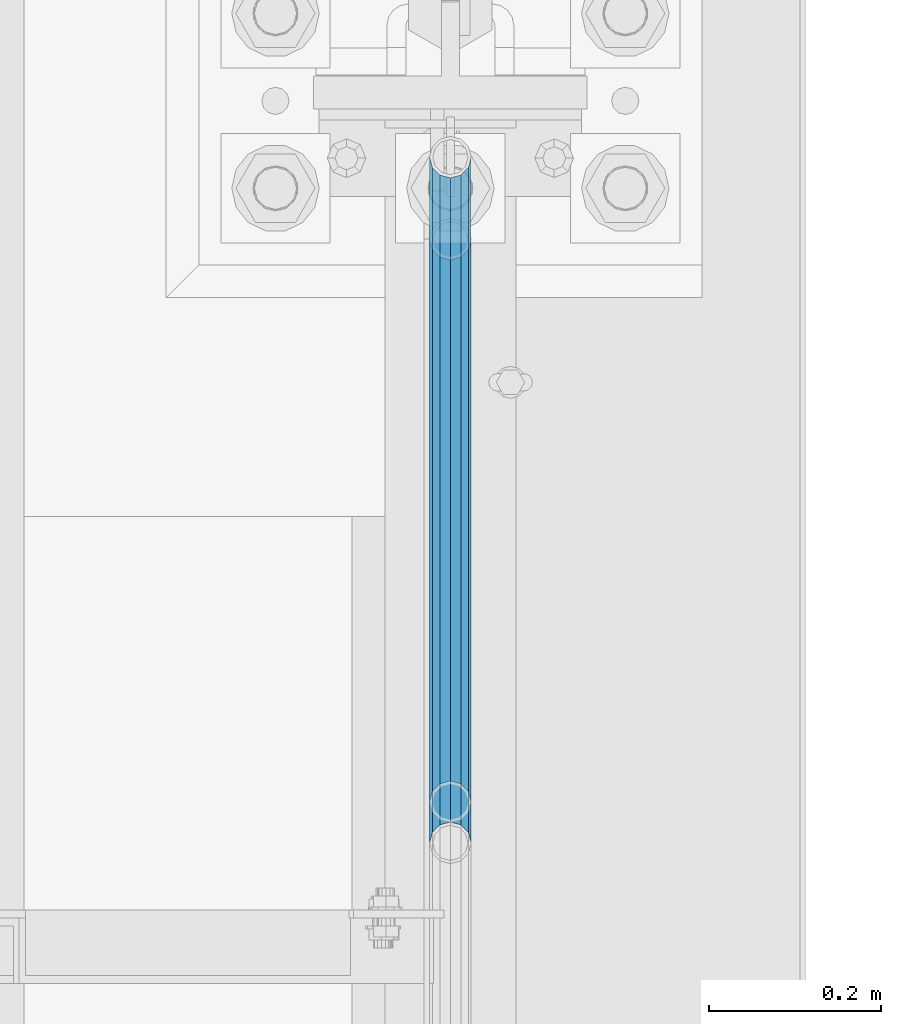
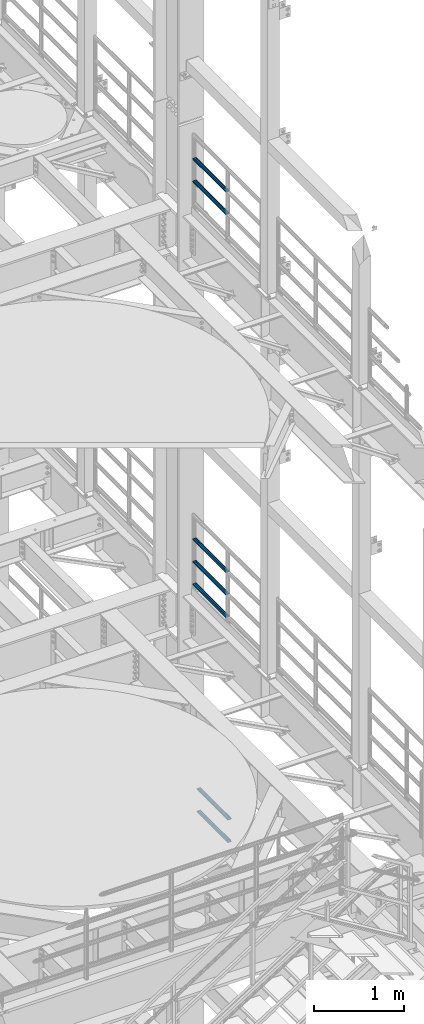
# One storey, part 1270 of 1876: 7 beams, 3 elements without a shape of their own.
"""IFC2X3 building model written with IfcOpenShell, lengths in millimetres."""

from ifc_helpers import new_model, si_unit, frame, origin_with_axes, place, context, subcontext, project, spatial, faceted_brep, material, type_object, element, aggregate, save


model = new_model("IFC2X3")

# Units and contexts
model_context = context("Model", 3, precision=1e-05, world=origin_with_axes())
body_context = subcontext(model_context, "Body", "Model", "MODEL_VIEW")
ifc_project = project(units=[si_unit("LENGTHUNIT", "METRE", prefix="MILLI"), si_unit("AREAUNIT", "SQUARE_METRE"), si_unit("VOLUMEUNIT", "CUBIC_METRE"), si_unit("MASSUNIT", "GRAM", prefix="KILO"), si_unit("TIMEUNIT", "SECOND"), si_unit("PLANEANGLEUNIT", "RADIAN"), si_unit("SOLIDANGLEUNIT", "STERADIAN"), si_unit("THERMODYNAMICTEMPERATUREUNIT", "DEGREE_CELSIUS"), si_unit("LUMINOUSINTENSITYUNIT", "LUMEN")], contexts=[model_context])

# Site, building, storey
site_placement = place(None, origin_with_axes())
site = spatial("IfcSite", under=ifc_project, at=site_placement, CompositionType="ELEMENT")
building_placement = place(site_placement, origin_with_axes())
building = spatial("IfcBuilding", under=site, at=building_placement, Name="Undefined", CompositionType="ELEMENT")
storey_placement = place(building_placement, origin_with_axes())
storey = spatial("IfcBuildingStorey", under=building, at=storey_placement, Name="Undefined", CompositionType="ELEMENT", Elevation=0.0)

# Assembly, beams
assembly_1_placement = place(storey_placement, origin_with_axes())
assembly_1 = element("IfcElementAssembly", 1, at=assembly_1_placement, inside=storey, Name="RAIL", AssemblyPlace="NOTDEFINED", PredefinedType="RIGID_FRAME")
ifc_material = material()
beam_type = type_object("IfcBeamType", Name="PIPE1-1/2SCH40", PredefinedType="NOTDEFINED")
beam_1_placement = place(assembly_1_placement, frame((7620.0, 430.212499999995, 13776.325), z_axis=(0.0, 0.0, -1.0), x_axis=(0.0, 1.0, 0.0)))
beam_1 = element("IfcBeam", 2, at=beam_1_placement, type_object=beam_type, material=ifc_material, Name="RAIL", ObjectType="PIPE1-1/2SCH40", context=body_context, shape_type="Brep", body=[
    faceted_brep([(0.0, 24.1299999999992, 0.0), (12.0650000000064, 20.8971929933177, -12.0649999999987), (12.0650000000064, 20.8971929933177, 12.0649999999987), (12.0650000000064, -20.8971929933177, 12.0649999999987), (12.0650000000064, -20.8971929933177, -12.0649999999987), (0.0, -24.1299999999992, 0.0), (20.8971929933249, -12.0650000000005, 20.8971929933177), (20.8971929933249, -12.0650000000005, 15.8661214311796), (15.2545715621445, -17.7076214311801, 10.2235000000001), (12.5151929933249, -20.4470000000001, 0.0), (15.2545715621445, -17.7076214311801, -10.2235000000001), (20.8971929933249, -12.0650000000005, -15.8661214311796), (20.8971929933249, -12.0650000000005, -20.8971929933177), (24.1300000000063, 0.0, -20.4470000000001), (24.1300000000063, 0.0, -24.130000000001), (21.3906214311868, -10.2235000000001, -17.7076214311819), (21.3906214311868, 10.2235000000001, -17.7076214311819), (20.8971929933249, 12.0650000000005, -15.8661214311796), (20.8971929933249, 12.0650000000005, -20.8971929933177), (15.2545715621445, 17.7076214311801, -10.2235000000001), (12.5151929933249, 20.4470000000001, 0.0), (15.2545715621445, 17.7076214311801, 10.2235000000001), (20.8971929933249, 12.0650000000005, 15.8661214311796), (20.8971929933249, 12.0650000000005, 20.8971929933177), (21.3906214311868, 10.2235000000001, 17.7076214311819), (24.1300000000064, 0.0, 20.4470000000001), (24.1300000000064, 0.0, 24.130000000001), (21.3906214311868, -10.2235000000001, 17.7076214311819), (748.982500000002, 24.1300000000001, 0.0), (736.917500000002, 20.8971929933186, -12.0649999999987), (728.085307006683, 12.0649999999996, -20.8971929933177), (748.982500000002, -24.1300000000001, 0.0), (736.917500000002, -20.8971929933186, -12.0649999999987), (736.917500000002, -20.8971929933186, 12.0649999999987), (728.085307006683, -12.0649999999996, 20.8971929933177), (728.085307006683, -12.0649999999996, -20.8971929933177), (724.852500000002, 0.0, -24.130000000001), (727.591878568821, 10.2235000000001, -17.7076214311819), (724.852500000002, 0.0, -20.4470000000001), (728.085307006683, 12.0649999999996, -15.8661214311796), (728.085307006683, -12.0649999999996, -15.8661214311796), (727.591878568821, -10.2235000000001, -17.7076214311819), (733.727928437864, -17.7076214311801, -10.2235000000001), (736.467307006683, -20.4470000000001, 0.0), (733.727928437864, -17.7076214311801, 10.2235000000001), (728.085307006683, -12.0649999999996, 15.8661214311796), (727.591878568821, -10.2235000000001, 17.7076214311819), (724.852500000002, 0.0, 20.4470000000001), (724.852500000002, 0.0, 24.130000000001), (728.085307006683, 12.0649999999996, 20.8971929933177), (736.917500000002, 20.8971929933186, 12.0649999999987), (728.085307006683, 12.0649999999996, 15.8661214311796), (733.727928437864, 17.7076214311801, 10.2235000000001), (736.467307006683, 20.4470000000001, 0.0), (733.727928437864, 17.7076214311801, -10.2235000000001), (727.591878568821, 10.2235000000001, 17.7076214311819)], [[[0, 1, 2]], [[3, 4, 5]], [[6, 7, 8, 9, 10, 11, 12, 4, 3]], [[13, 14, 12, 11, 15]], [[16, 17, 18, 14, 13]], [[2, 1, 18, 17, 19, 20, 21, 22, 23]], [[23, 22, 24, 25, 26]], [[26, 25, 27, 7, 6]], [[1, 0, 28, 29]], [[18, 1, 29, 30]], [[31, 32, 33]], [[6, 3, 33, 34]], [[3, 5, 31, 33]], [[5, 4, 32, 31]], [[4, 12, 35, 32]], [[12, 14, 36, 35]], [[14, 18, 30, 36]], [[37, 38, 36, 30, 39]], [[40, 35, 36, 38, 41]], [[33, 32, 35, 40, 42, 43, 44, 45, 34]], [[34, 45, 46, 47, 48]], [[26, 6, 34, 48]], [[2, 23, 49, 50]], [[23, 26, 48, 49]], [[0, 2, 50, 28]], [[28, 50, 29]], [[49, 51, 52, 53, 54, 39, 30, 29, 50]], [[48, 47, 55, 51, 49]], [[25, 24, 55, 47]], [[55, 24, 22, 21, 52, 51]], [[21, 20, 53, 52]], [[20, 19, 54, 53]], [[19, 17, 16, 37, 39, 54]], [[16, 13, 38, 37]], [[13, 15, 41, 38]], [[41, 15, 11, 10, 42, 40]], [[10, 9, 43, 42]], [[9, 8, 44, 43]], [[8, 7, 27, 46, 45, 44]], [[27, 25, 47, 46]]]),
])
beam_2_placement = place(assembly_1_placement, frame((7620.0, 430.212499999995, 14081.125), z_axis=(0.0, 0.0, -1.0), x_axis=(0.0, 1.0, 0.0)))
beam_2 = element("IfcBeam", 3, at=beam_2_placement, type_object=beam_type, material=ifc_material, Name="RAIL", ObjectType="PIPE1-1/2SCH40", context=body_context, shape_type="Brep", body=[
    faceted_brep([(0.0, 24.1299999999992, 0.0), (12.0650000000064, 20.8971929933177, -12.0649999999987), (12.0650000000064, 20.8971929933177, 12.0649999999987), (12.0650000000064, -20.8971929933177, 12.0649999999987), (12.0650000000064, -20.8971929933177, -12.0649999999987), (0.0, -24.1299999999992, 0.0), (20.8971929933249, -12.0650000000005, 20.8971929933177), (20.8971929933249, -12.0650000000005, 15.8661214311796), (15.2545715621445, -17.7076214311801, 10.2235000000001), (12.5151929933249, -20.4470000000001, 0.0), (15.2545715621445, -17.7076214311801, -10.2235000000001), (20.8971929933249, -12.0650000000005, -15.8661214311796), (20.8971929933249, -12.0650000000005, -20.8971929933177), (24.1300000000063, 0.0, -20.4470000000001), (24.1300000000063, 0.0, -24.130000000001), (21.3906214311868, -10.2235000000001, -17.7076214311819), (21.3906214311868, 10.2235000000001, -17.7076214311819), (20.8971929933249, 12.0650000000005, -15.8661214311796), (20.8971929933249, 12.0650000000005, -20.8971929933177), (15.2545715621445, 17.7076214311801, -10.2235000000001), (12.5151929933249, 20.4470000000001, 0.0), (15.2545715621445, 17.7076214311801, 10.2235000000001), (20.8971929933249, 12.0650000000005, 15.8661214311796), (20.8971929933249, 12.0650000000005, 20.8971929933177), (21.3906214311868, 10.2235000000001, 17.7076214311819), (24.1300000000064, 0.0, 20.4470000000001), (24.1300000000064, 0.0, 24.130000000001), (21.3906214311868, -10.2235000000001, 17.7076214311819), (748.982500000002, 24.1300000000001, 0.0), (736.917500000002, 20.8971929933186, -12.0649999999987), (728.085307006683, 12.0649999999996, -20.8971929933177), (748.982500000002, -24.1300000000001, 0.0), (736.917500000002, -20.8971929933186, -12.0649999999987), (736.917500000002, -20.8971929933186, 12.0649999999987), (728.085307006683, -12.0649999999996, 20.8971929933177), (728.085307006683, -12.0649999999996, -20.8971929933177), (724.852500000002, 0.0, -24.130000000001), (727.591878568821, 10.2235000000001, -17.7076214311819), (724.852500000002, 0.0, -20.4470000000001), (728.085307006683, 12.0649999999996, -15.8661214311796), (728.085307006683, -12.0649999999996, -15.8661214311796), (727.591878568821, -10.2235000000001, -17.7076214311819), (733.727928437864, -17.7076214311801, -10.2235000000001), (736.467307006683, -20.4470000000001, 0.0), (733.727928437864, -17.7076214311801, 10.2235000000001), (728.085307006683, -12.0649999999996, 15.8661214311796), (727.591878568821, -10.2235000000001, 17.7076214311819), (724.852500000002, 0.0, 20.4470000000001), (724.852500000002, 0.0, 24.130000000001), (728.085307006683, 12.0649999999996, 20.8971929933177), (736.917500000002, 20.8971929933186, 12.0649999999987), (728.085307006683, 12.0649999999996, 15.8661214311796), (733.727928437864, 17.7076214311801, 10.2235000000001), (736.467307006683, 20.4470000000001, 0.0), (733.727928437864, 17.7076214311801, -10.2235000000001), (727.591878568821, 10.2235000000001, 17.7076214311819)], [[[0, 1, 2]], [[3, 4, 5]], [[6, 7, 8, 9, 10, 11, 12, 4, 3]], [[13, 14, 12, 11, 15]], [[16, 17, 18, 14, 13]], [[2, 1, 18, 17, 19, 20, 21, 22, 23]], [[23, 22, 24, 25, 26]], [[26, 25, 27, 7, 6]], [[1, 0, 28, 29]], [[18, 1, 29, 30]], [[31, 32, 33]], [[6, 3, 33, 34]], [[3, 5, 31, 33]], [[5, 4, 32, 31]], [[4, 12, 35, 32]], [[12, 14, 36, 35]], [[14, 18, 30, 36]], [[37, 38, 36, 30, 39]], [[40, 35, 36, 38, 41]], [[33, 32, 35, 40, 42, 43, 44, 45, 34]], [[34, 45, 46, 47, 48]], [[26, 6, 34, 48]], [[2, 23, 49, 50]], [[23, 26, 48, 49]], [[0, 2, 50, 28]], [[28, 50, 29]], [[49, 51, 52, 53, 54, 39, 30, 29, 50]], [[48, 47, 55, 51, 49]], [[25, 24, 55, 47]], [[55, 24, 22, 21, 52, 51]], [[21, 20, 53, 52]], [[20, 19, 54, 53]], [[19, 17, 16, 37, 39, 54]], [[16, 13, 38, 37]], [[13, 15, 41, 38]], [[41, 15, 11, 10, 42, 40]], [[10, 9, 43, 42]], [[9, 8, 44, 43]], [[8, 7, 27, 46, 45, 44]], [[27, 25, 47, 46]]]),
])
aggregate(assembly_1, [beam_1, beam_2])

assembly_2_placement = place(storey_placement, origin_with_axes())
assembly_2 = element("IfcElementAssembly", 4, at=assembly_2_placement, inside=storey, Name="RAIL", AssemblyPlace="NOTDEFINED", PredefinedType="RIGID_FRAME")
beam_3_placement = place(assembly_2_placement, frame((7619.99999999999, 1179.195, 8315.325), z_axis=(0.0, 0.0, 1.0), x_axis=(0.0, -1.0, 0.0)))
beam_3 = element("IfcBeam", 5, at=beam_3_placement, type_object=beam_type, material=ifc_material, Name="RAIL", ObjectType="PIPE1-1/2SCH40", context=body_context, shape_type="Brep", body=[
    faceted_brep([(728.085307006683, -12.0649999999996, 20.8971929933177), (728.085307006683, -12.0649999999996, 15.8661214311796), (727.591878568821, -10.2235000000001, 17.7076214311819), (724.852500000002, 0.0, 20.4470000000001), (724.852500000002, 0.0, 24.130000000001), (727.591878568821, 10.2235000000001, 17.7076214311819), (728.085307006683, 12.0649999999996, 15.8661214311796), (728.085307006683, 12.0649999999996, 20.8971929933177), (748.982500000002, 24.1300000000001, 0.0), (736.917500000002, 20.8971929933186, 12.0649999999987), (736.917500000002, 20.8971929933186, -12.0649999999987), (733.727928437864, 17.7076214311801, 10.2235000000001), (736.467307006683, 20.4470000000001, 0.0), (733.727928437864, 17.7076214311801, -10.2235000000001), (728.085307006683, 12.0649999999996, -15.8661214311796), (728.085307006683, 12.0649999999996, -20.8971929933177), (727.591878568821, 10.2235000000001, -17.7076214311819), (724.852500000002, 0.0, -20.4470000000001), (724.852500000002, 0.0, -24.130000000001), (728.085307006683, -12.0649999999996, -15.8661214311796), (728.085307006683, -12.0649999999996, -20.8971929933177), (727.591878568821, -10.2235000000001, -17.7076214311819), (748.982500000002, -24.1300000000001, 0.0), (736.917500000002, -20.8971929933186, -12.0649999999987), (736.917500000002, -20.8971929933186, 12.0649999999987), (733.727928437864, -17.7076214311801, -10.2235000000001), (736.467307006683, -20.4470000000001, 0.0), (733.727928437864, -17.7076214311801, 10.2235000000001), (12.0650000000064, -20.8971929933177, -12.0649999999987), (20.8971929933249, -12.0650000000005, -20.8971929933177), (0.0, 24.1299999999992, 0.0), (12.0650000000064, 20.8971929933177, -12.0649999999987), (12.0650000000064, 20.8971929933177, 12.0649999999987), (20.8971929933249, 12.0650000000005, 20.8971929933177), (24.1300000000064, 0.0, 24.130000000001), (20.8971929933249, 12.0650000000005, -20.8971929933177), (24.1300000000063, 0.0, -24.130000000001), (24.1300000000063, 0.0, -20.4470000000001), (20.8971929933249, -12.0650000000005, -15.8661214311796), (21.3906214311868, -10.2235000000001, -17.7076214311819), (21.3906214311868, 10.2235000000001, -17.7076214311819), (20.8971929933249, 12.0650000000005, -15.8661214311796), (15.2545715621445, 17.7076214311801, -10.2235000000001), (12.5151929933249, 20.4470000000001, 0.0), (15.2545715621445, 17.7076214311801, 10.2235000000001), (20.8971929933249, 12.0650000000005, 15.8661214311796), (21.3906214311868, 10.2235000000001, 17.7076214311819), (24.1300000000064, 0.0, 20.4470000000001), (21.3906214311868, -10.2235000000001, 17.7076214311819), (20.8971929933249, -12.0650000000005, 15.8661214311796), (20.8971929933249, -12.0650000000005, 20.8971929933177), (12.0650000000064, -20.8971929933177, 12.0649999999987), (0.0, -24.1299999999992, 0.0), (15.2545715621445, -17.7076214311801, 10.2235000000001), (12.5151929933249, -20.4470000000001, 0.0), (15.2545715621445, -17.7076214311801, -10.2235000000001)], [[[0, 1, 2, 3, 4]], [[4, 3, 5, 6, 7]], [[8, 9, 10]], [[7, 6, 11, 12, 13, 14, 15, 10, 9]], [[16, 17, 18, 15, 14]], [[19, 20, 18, 17, 21]], [[22, 23, 24]], [[24, 23, 20, 19, 25, 26, 27, 1, 0]], [[28, 29, 20, 23]], [[30, 31, 32]], [[33, 34, 4, 7]], [[32, 33, 7, 9]], [[30, 32, 9, 8]], [[31, 30, 8, 10]], [[35, 31, 10, 15]], [[36, 35, 15, 18]], [[29, 36, 18, 20]], [[37, 36, 29, 38, 39]], [[40, 41, 35, 36, 37]], [[32, 31, 35, 41, 42, 43, 44, 45, 33]], [[33, 45, 46, 47, 34]], [[34, 47, 48, 49, 50]], [[34, 50, 0, 4]], [[50, 51, 24, 0]], [[51, 52, 22, 24]], [[52, 28, 23, 22]], [[51, 28, 52]], [[50, 49, 53, 54, 55, 38, 29, 28, 51]], [[55, 54, 26, 25]], [[21, 39, 38, 55, 25, 19]], [[37, 39, 21, 17]], [[40, 37, 17, 16]], [[42, 41, 40, 16, 14, 13]], [[43, 42, 13, 12]], [[44, 43, 12, 11]], [[5, 46, 45, 44, 11, 6]], [[47, 46, 5, 3]], [[48, 47, 3, 2]], [[53, 49, 48, 2, 1, 27]], [[54, 53, 27, 26]]]),
])
beam_4_placement = place(assembly_2_placement, frame((7620.0, 430.212499999999, 8620.125), z_axis=(0.0, 0.0, -1.0), x_axis=(0.0, 1.0, 0.0)))
beam_4 = element("IfcBeam", 6, at=beam_4_placement, type_object=beam_type, material=ifc_material, Name="RAIL", ObjectType="PIPE1-1/2SCH40", context=body_context, shape_type="Brep", body=[
    faceted_brep([(0.0, 24.1299999999992, 0.0), (12.0650000000064, 20.8971929933177, -12.0649999999987), (12.0650000000064, 20.8971929933177, 12.0649999999987), (12.0650000000064, -20.8971929933177, 12.0649999999987), (12.0650000000064, -20.8971929933177, -12.0649999999987), (0.0, -24.1299999999992, 0.0), (20.8971929933249, -12.0650000000005, 20.8971929933177), (20.8971929933249, -12.0650000000005, 15.8661214311796), (15.2545715621445, -17.7076214311801, 10.2235000000001), (12.5151929933249, -20.4470000000001, 0.0), (15.2545715621445, -17.7076214311801, -10.2235000000001), (20.8971929933249, -12.0650000000005, -15.8661214311796), (20.8971929933249, -12.0650000000005, -20.8971929933177), (24.1300000000063, 0.0, -20.4470000000001), (24.1300000000063, 0.0, -24.130000000001), (21.3906214311868, -10.2235000000001, -17.7076214311819), (21.3906214311868, 10.2235000000001, -17.7076214311819), (20.8971929933249, 12.0650000000005, -15.8661214311796), (20.8971929933249, 12.0650000000005, -20.8971929933177), (15.2545715621445, 17.7076214311801, -10.2235000000001), (12.5151929933249, 20.4470000000001, 0.0), (15.2545715621445, 17.7076214311801, 10.2235000000001), (20.8971929933249, 12.0650000000005, 15.8661214311796), (20.8971929933249, 12.0650000000005, 20.8971929933177), (21.3906214311868, 10.2235000000001, 17.7076214311819), (24.1300000000064, 0.0, 20.4470000000001), (24.1300000000064, 0.0, 24.130000000001), (21.3906214311868, -10.2235000000001, 17.7076214311819), (748.982500000002, 24.1300000000001, 0.0), (736.917500000002, 20.8971929933186, -12.0649999999987), (728.085307006683, 12.0649999999996, -20.8971929933177), (748.982500000002, -24.1300000000001, 0.0), (736.917500000002, -20.8971929933186, -12.0649999999987), (736.917500000002, -20.8971929933186, 12.0649999999987), (728.085307006683, -12.0649999999996, 20.8971929933177), (728.085307006683, -12.0649999999996, -20.8971929933177), (724.852500000002, 0.0, -24.130000000001), (727.591878568821, 10.2235000000001, -17.7076214311819), (724.852500000002, 0.0, -20.4470000000001), (728.085307006683, 12.0649999999996, -15.8661214311796), (728.085307006683, -12.0649999999996, -15.8661214311796), (727.591878568821, -10.2235000000001, -17.7076214311819), (733.727928437864, -17.7076214311801, -10.2235000000001), (736.467307006683, -20.4470000000001, 0.0), (733.727928437864, -17.7076214311801, 10.2235000000001), (728.085307006683, -12.0649999999996, 15.8661214311796), (727.591878568821, -10.2235000000001, 17.7076214311819), (724.852500000002, 0.0, 20.4470000000001), (724.852500000002, 0.0, 24.130000000001), (728.085307006683, 12.0649999999996, 20.8971929933177), (736.917500000002, 20.8971929933186, 12.0649999999987), (728.085307006683, 12.0649999999996, 15.8661214311796), (733.727928437864, 17.7076214311801, 10.2235000000001), (736.467307006683, 20.4470000000001, 0.0), (733.727928437864, 17.7076214311801, -10.2235000000001), (727.591878568821, 10.2235000000001, 17.7076214311819)], [[[0, 1, 2]], [[3, 4, 5]], [[6, 7, 8, 9, 10, 11, 12, 4, 3]], [[13, 14, 12, 11, 15]], [[16, 17, 18, 14, 13]], [[2, 1, 18, 17, 19, 20, 21, 22, 23]], [[23, 22, 24, 25, 26]], [[26, 25, 27, 7, 6]], [[1, 0, 28, 29]], [[18, 1, 29, 30]], [[31, 32, 33]], [[6, 3, 33, 34]], [[3, 5, 31, 33]], [[5, 4, 32, 31]], [[4, 12, 35, 32]], [[12, 14, 36, 35]], [[14, 18, 30, 36]], [[37, 38, 36, 30, 39]], [[40, 35, 36, 38, 41]], [[33, 32, 35, 40, 42, 43, 44, 45, 34]], [[34, 45, 46, 47, 48]], [[26, 6, 34, 48]], [[2, 23, 49, 50]], [[23, 26, 48, 49]], [[0, 2, 50, 28]], [[28, 50, 29]], [[49, 51, 52, 53, 54, 39, 30, 29, 50]], [[48, 47, 55, 51, 49]], [[25, 24, 55, 47]], [[55, 24, 22, 21, 52, 51]], [[21, 20, 53, 52]], [[20, 19, 54, 53]], [[19, 17, 16, 37, 39, 54]], [[16, 13, 38, 37]], [[13, 15, 41, 38]], [[41, 15, 11, 10, 42, 40]], [[10, 9, 43, 42]], [[9, 8, 44, 43]], [[8, 7, 27, 46, 45, 44]], [[27, 25, 47, 46]]]),
])
beam_5_placement = place(assembly_2_placement, frame((7620.0, 430.212499999999, 8924.925), z_axis=(0.0, 0.0, -1.0), x_axis=(0.0, 1.0, 0.0)))
beam_5 = element("IfcBeam", 7, at=beam_5_placement, type_object=beam_type, material=ifc_material, Name="RAIL", ObjectType="PIPE1-1/2SCH40", context=body_context, shape_type="Brep", body=[
    faceted_brep([(0.0, 24.1299999999992, 0.0), (12.0650000000064, 20.8971929933177, -12.0649999999987), (12.0650000000064, 20.8971929933177, 12.0649999999987), (12.0650000000064, -20.8971929933177, 12.0649999999987), (12.0650000000064, -20.8971929933177, -12.0649999999987), (0.0, -24.1299999999992, 0.0), (20.8971929933249, -12.0650000000005, 20.8971929933177), (20.8971929933249, -12.0650000000005, 15.8661214311796), (15.2545715621445, -17.7076214311801, 10.2235000000001), (12.5151929933249, -20.4470000000001, 0.0), (15.2545715621445, -17.7076214311801, -10.2235000000001), (20.8971929933249, -12.0650000000005, -15.8661214311796), (20.8971929933249, -12.0650000000005, -20.8971929933177), (24.1300000000063, 0.0, -20.4470000000001), (24.1300000000063, 0.0, -24.130000000001), (21.3906214311868, -10.2235000000001, -17.7076214311819), (21.3906214311868, 10.2235000000001, -17.7076214311819), (20.8971929933249, 12.0650000000005, -15.8661214311796), (20.8971929933249, 12.0650000000005, -20.8971929933177), (15.2545715621445, 17.7076214311801, -10.2235000000001), (12.5151929933249, 20.4470000000001, 0.0), (15.2545715621445, 17.7076214311801, 10.2235000000001), (20.8971929933249, 12.0650000000005, 15.8661214311796), (20.8971929933249, 12.0650000000005, 20.8971929933177), (21.3906214311868, 10.2235000000001, 17.7076214311819), (24.1300000000064, 0.0, 20.4470000000001), (24.1300000000064, 0.0, 24.130000000001), (21.3906214311868, -10.2235000000001, 17.7076214311819), (748.982500000002, 24.1300000000001, 0.0), (736.917500000002, 20.8971929933186, -12.0649999999987), (728.085307006683, 12.0649999999996, -20.8971929933177), (748.982500000002, -24.1300000000001, 0.0), (736.917500000002, -20.8971929933186, -12.0649999999987), (736.917500000002, -20.8971929933186, 12.0649999999987), (728.085307006683, -12.0649999999996, 20.8971929933177), (728.085307006683, -12.0649999999996, -20.8971929933177), (724.852500000002, 0.0, -24.130000000001), (727.591878568821, 10.2235000000001, -17.7076214311819), (724.852500000002, 0.0, -20.4470000000001), (728.085307006683, 12.0649999999996, -15.8661214311796), (728.085307006683, -12.0649999999996, -15.8661214311796), (727.591878568821, -10.2235000000001, -17.7076214311819), (733.727928437864, -17.7076214311801, -10.2235000000001), (736.467307006683, -20.4470000000001, 0.0), (733.727928437864, -17.7076214311801, 10.2235000000001), (728.085307006683, -12.0649999999996, 15.8661214311796), (727.591878568821, -10.2235000000001, 17.7076214311819), (724.852500000002, 0.0, 20.4470000000001), (724.852500000002, 0.0, 24.130000000001), (728.085307006683, 12.0649999999996, 20.8971929933177), (736.917500000002, 20.8971929933186, 12.0649999999987), (728.085307006683, 12.0649999999996, 15.8661214311796), (733.727928437864, 17.7076214311801, 10.2235000000001), (736.467307006683, 20.4470000000001, 0.0), (733.727928437864, 17.7076214311801, -10.2235000000001), (727.591878568821, 10.2235000000001, 17.7076214311819)], [[[0, 1, 2]], [[3, 4, 5]], [[6, 7, 8, 9, 10, 11, 12, 4, 3]], [[13, 14, 12, 11, 15]], [[16, 17, 18, 14, 13]], [[2, 1, 18, 17, 19, 20, 21, 22, 23]], [[23, 22, 24, 25, 26]], [[26, 25, 27, 7, 6]], [[1, 0, 28, 29]], [[18, 1, 29, 30]], [[31, 32, 33]], [[6, 3, 33, 34]], [[3, 5, 31, 33]], [[5, 4, 32, 31]], [[4, 12, 35, 32]], [[12, 14, 36, 35]], [[14, 18, 30, 36]], [[37, 38, 36, 30, 39]], [[40, 35, 36, 38, 41]], [[33, 32, 35, 40, 42, 43, 44, 45, 34]], [[34, 45, 46, 47, 48]], [[26, 6, 34, 48]], [[2, 23, 49, 50]], [[23, 26, 48, 49]], [[0, 2, 50, 28]], [[28, 50, 29]], [[49, 51, 52, 53, 54, 39, 30, 29, 50]], [[48, 47, 55, 51, 49]], [[25, 24, 55, 47]], [[55, 24, 22, 21, 52, 51]], [[21, 20, 53, 52]], [[20, 19, 54, 53]], [[19, 17, 16, 37, 39, 54]], [[16, 13, 38, 37]], [[13, 15, 41, 38]], [[41, 15, 11, 10, 42, 40]], [[10, 9, 43, 42]], [[9, 8, 44, 43]], [[8, 7, 27, 46, 45, 44]], [[27, 25, 47, 46]]]),
])
aggregate(assembly_2, [beam_3, beam_4, beam_5])

assembly_3_placement = place(storey_placement, origin_with_axes())
assembly_3 = element("IfcElementAssembly", 8, at=assembly_3_placement, inside=storey, Name="RAIL", AssemblyPlace="NOTDEFINED", PredefinedType="RIGID_FRAME")
beam_6_placement = place(assembly_3_placement, frame((7620.00000000007, 382.569831680697, 5292.73091229414), z_axis=(0.0, -8.42999999986204e-06, 0.999999999964468), x_axis=(0.0, 0.999999999964468, 8.43000000018809e-06)))
beam_6 = element("IfcBeam", 9, at=beam_6_placement, type_object=beam_type, material=ifc_material, Name="RAIL", ObjectType="PIPE1-1/2SCH40", context=body_context, shape_type="Brep", body=[
    faceted_brep([(680.442814874983, -12.0649999999996, 20.8971929933068), (680.44277246305, -12.0649999999277, 15.8661214312397), (679.949359549034, -10.2235000000001, 17.7076214311674), (677.210004073059, 2.72848410531878e-12, 20.4469999999883), (677.210035120749, 2.72848410531878e-12, 24.1299999999883), (679.949359548996, 10.2235000000001, 17.7076214311674), (680.44277246305, 12.0650000000714, 15.866121431096), (680.442814874983, 12.0649999999996, 20.8971929933068), (701.33983170571, 24.1300000000001, -1.45519152283669e-11), (689.27493341323, 20.8971929933186, 12.0649999999878), (689.27472999733, 20.8971929933186, -12.0650000000151), (686.085346327061, 17.7076214311801, 10.2234999999873), (688.824638711873, 20.4470000000001, -1.36424205265939e-11), (686.085173958852, 17.7076214311801, -10.2235000000137), (680.442504960242, 12.0650000000714, -15.8661214311223), (680.442462548309, 12.0649999999996, -20.8971929933323), (679.949060998498, 10.2235000000001, -17.7076214311946), (677.20965933664, 0.0, -20.4470000000147), (677.20962828895, 0.0, -24.1300000000147), (680.442504960242, -12.0649999999277, -15.866121431266), (680.442462548309, -12.0649999999996, -20.8971929933323), (679.949060998536, -10.2235000000001, -17.7076214311946), (701.33983170571, -24.1299999999283, -1.45519152283669e-11), (689.27472999733, -20.8971929933186, -12.0650000000151), (689.27493341323, -20.8971929933186, 12.0649999999878), (686.085173958994, -17.7076214311801, -10.2235000000137), (688.824638712016, -20.4470000000001, -1.36424205265939e-11), (686.085346327204, -17.7076214311801, 10.2234999999873), (12.0648982924813, -20.8971929933186, -12.0650000000005), (20.8970168307269, -12.0649999999996, -20.8971929933195), (0.0, 24.1299999999992, 0.0), (12.0648982924813, 20.8971929933186, -12.0650000000005), (12.065101708381, 20.8971929933186, 12.0650000000005), (20.897369157401, 12.0649999999996, 20.8971929933205), (24.1302034167611, 7.18500814400613e-11, 24.1300000000019), (20.8970168307269, 12.0649999999996, -20.8971929933195), (24.1297965849608, 0.0, -24.130000000001), (24.1298276326506, 0.0, -20.447000000001), (20.8970592426604, -12.0649999999277, -15.8661214312533), (21.390472156676, -10.2235000000001, -17.7076214311819), (21.3904721567151, 10.2235000000001, -17.7076214311819), (20.8970592426604, 12.0650000000714, -15.8661214311096), (15.2544853786503, 17.7076214311801, -10.2235000000001), (12.5151929933249, 20.4470000000001, 0.0), (15.2546577468602, 17.7076214311801, 10.223500000001), (20.8973267454676, 12.0650000000714, 15.8661214311096), (21.3907707072121, 10.2235000000001, 17.7076214311819), (24.1301723690713, 7.18500814400613e-11, 20.447000000001), (21.390770707173, -10.2235000000001, 17.7076214311819), (20.8973267454676, -12.0649999999277, 15.8661214312533), (20.897369157401, -12.0649999999996, 20.8971929933205), (12.065101708381, -20.8971929933186, 12.0650000000005), (0.0, -24.1299999999992, 0.0), (15.2546577467156, -17.7076214311801, 10.223500000001), (12.5151929933249, -20.4470000000001, 0.0), (15.2544853785057, -17.7076214311801, -10.2235000000001)], [[[0, 1, 2, 3, 4]], [[4, 3, 5, 6, 7]], [[8, 9, 10]], [[7, 6, 11, 12, 13, 14, 15, 10, 9]], [[16, 17, 18, 15, 14]], [[19, 20, 18, 17, 21]], [[22, 23, 24]], [[24, 23, 20, 19, 25, 26, 27, 1, 0]], [[28, 29, 20, 23]], [[30, 31, 32]], [[33, 34, 4, 7]], [[32, 33, 7, 9]], [[30, 32, 9, 8]], [[31, 30, 8, 10]], [[35, 31, 10, 15]], [[36, 35, 15, 18]], [[29, 36, 18, 20]], [[37, 36, 29, 38, 39]], [[40, 41, 35, 36, 37]], [[32, 31, 35, 41, 42, 43, 44, 45, 33]], [[33, 45, 46, 47, 34]], [[34, 47, 48, 49, 50]], [[34, 50, 0, 4]], [[50, 51, 24, 0]], [[51, 52, 22, 24]], [[52, 28, 23, 22]], [[51, 28, 52]], [[50, 49, 53, 54, 55, 38, 29, 28, 51]], [[55, 54, 26, 25]], [[21, 39, 38, 55, 25, 19]], [[37, 39, 21, 17]], [[40, 37, 17, 16]], [[42, 41, 40, 16, 14, 13]], [[43, 42, 13, 12]], [[44, 43, 12, 11]], [[5, 46, 45, 44, 11, 6]], [[47, 46, 5, 3]], [[48, 47, 3, 2]], [[53, 49, 48, 2, 1, 27]], [[54, 53, 27, 26]]]),
])
beam_7_placement = place(assembly_3_placement, frame((7620.00000000031, 1083.9096633614, 5597.53682459919), z_axis=(0.0, 7.91400000045761e-06, -0.999999999968684), x_axis=(0.0, -0.999999999968684, -7.91400000071008e-06)))
beam_7 = element("IfcBeam", 10, at=beam_7_placement, type_object=beam_type, material=ifc_material, Name="RAIL", ObjectType="PIPE1-1/2SCH40", context=body_context, shape_type="Brep", body=[
    faceted_brep([(0.0, 24.1299999999992, 0.0), (12.0648982924813, 20.8971929933186, -12.0650000000005), (12.065101708381, 20.8971929933186, 12.0650000000005), (12.065101708381, -20.8971929933186, 12.0650000000005), (12.0648982924813, -20.8971929933186, -12.0650000000005), (0.0, -24.1299999999992, 0.0), (20.897369157401, -12.0649999999996, 20.8971929933205), (20.8973267454676, -12.0649999999277, 15.8661214312533), (15.2546577467156, -17.7076214311801, 10.223500000001), (12.5151929933249, -20.4470000000001, 0.0), (15.2544853785057, -17.7076214311801, -10.2235000000001), (20.8970592426604, -12.0649999999277, -15.8661214312533), (20.8970168307269, -12.0649999999996, -20.8971929933195), (24.1298276326506, 0.0, -20.447000000001), (24.1297965849608, 0.0, -24.130000000001), (21.390472156676, -10.2235000000001, -17.7076214311819), (21.3904721567151, 10.2235000000001, -17.7076214311819), (20.8970592426604, 12.0650000000714, -15.8661214311096), (20.8970168307269, 12.0649999999996, -20.8971929933195), (15.2544853786503, 17.7076214311801, -10.2235000000001), (12.5151929933249, 20.4470000000001, 0.0), (15.2546577468602, 17.7076214311801, 10.223500000001), (20.8973267454676, 12.0650000000714, 15.8661214311096), (20.897369157401, 12.0649999999996, 20.8971929933205), (21.3907707072121, 10.2235000000001, 17.7076214311819), (24.1301723690713, 7.18500814400613e-11, 20.447000000001), (24.1302034167611, 7.18500814400613e-11, 24.1300000000019), (21.390770707173, -10.2235000000001, 17.7076214311819), (701.33983170571, 24.1300000000001, -1.45519152283669e-11), (689.27472999733, 20.8971929933186, -12.0650000000151), (680.442462548309, 12.0649999999996, -20.8971929933323), (701.33983170571, -24.1299999999283, -1.45519152283669e-11), (689.27472999733, -20.8971929933186, -12.0650000000151), (689.27493341323, -20.8971929933186, 12.0649999999878), (680.442814874983, -12.0649999999996, 20.8971929933068), (680.442462548309, -12.0649999999996, -20.8971929933323), (677.20962828895, 0.0, -24.1300000000147), (679.949060998498, 10.2235000000001, -17.7076214311946), (677.20965933664, 0.0, -20.4470000000147), (680.442504960242, 12.0650000000714, -15.8661214311223), (680.442504960242, -12.0649999999277, -15.866121431266), (679.949060998536, -10.2235000000001, -17.7076214311946), (686.085173958994, -17.7076214311801, -10.2235000000137), (688.824638712016, -20.4470000000001, -1.36424205265939e-11), (686.085346327204, -17.7076214311801, 10.2234999999873), (680.44277246305, -12.0649999999277, 15.8661214312397), (679.949359549034, -10.2235000000001, 17.7076214311674), (677.210004073059, 2.72848410531878e-12, 20.4469999999883), (677.210035120749, 2.72848410531878e-12, 24.1299999999883), (680.442814874983, 12.0649999999996, 20.8971929933068), (689.27493341323, 20.8971929933186, 12.0649999999878), (680.44277246305, 12.0650000000714, 15.866121431096), (686.085346327061, 17.7076214311801, 10.2234999999873), (688.824638711873, 20.4470000000001, -1.36424205265939e-11), (686.085173958852, 17.7076214311801, -10.2235000000137), (679.949359548996, 10.2235000000001, 17.7076214311674)], [[[0, 1, 2]], [[3, 4, 5]], [[6, 7, 8, 9, 10, 11, 12, 4, 3]], [[13, 14, 12, 11, 15]], [[16, 17, 18, 14, 13]], [[2, 1, 18, 17, 19, 20, 21, 22, 23]], [[23, 22, 24, 25, 26]], [[26, 25, 27, 7, 6]], [[1, 0, 28, 29]], [[18, 1, 29, 30]], [[31, 32, 33]], [[6, 3, 33, 34]], [[3, 5, 31, 33]], [[5, 4, 32, 31]], [[4, 12, 35, 32]], [[12, 14, 36, 35]], [[14, 18, 30, 36]], [[37, 38, 36, 30, 39]], [[40, 35, 36, 38, 41]], [[33, 32, 35, 40, 42, 43, 44, 45, 34]], [[34, 45, 46, 47, 48]], [[26, 6, 34, 48]], [[2, 23, 49, 50]], [[23, 26, 48, 49]], [[0, 2, 50, 28]], [[28, 50, 29]], [[49, 51, 52, 53, 54, 39, 30, 29, 50]], [[48, 47, 55, 51, 49]], [[25, 24, 55, 47]], [[55, 24, 22, 21, 52, 51]], [[21, 20, 53, 52]], [[20, 19, 54, 53]], [[19, 17, 16, 37, 39, 54]], [[16, 13, 38, 37]], [[13, 15, 41, 38]], [[41, 15, 11, 10, 42, 40]], [[10, 9, 43, 42]], [[9, 8, 44, 43]], [[8, 7, 27, 46, 45, 44]], [[27, 25, 47, 46]]]),
])
aggregate(assembly_3, [beam_6, beam_7])

save(model, "model.ifc")
